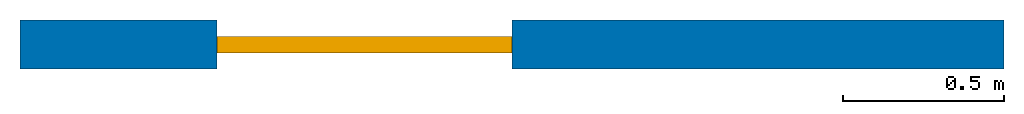
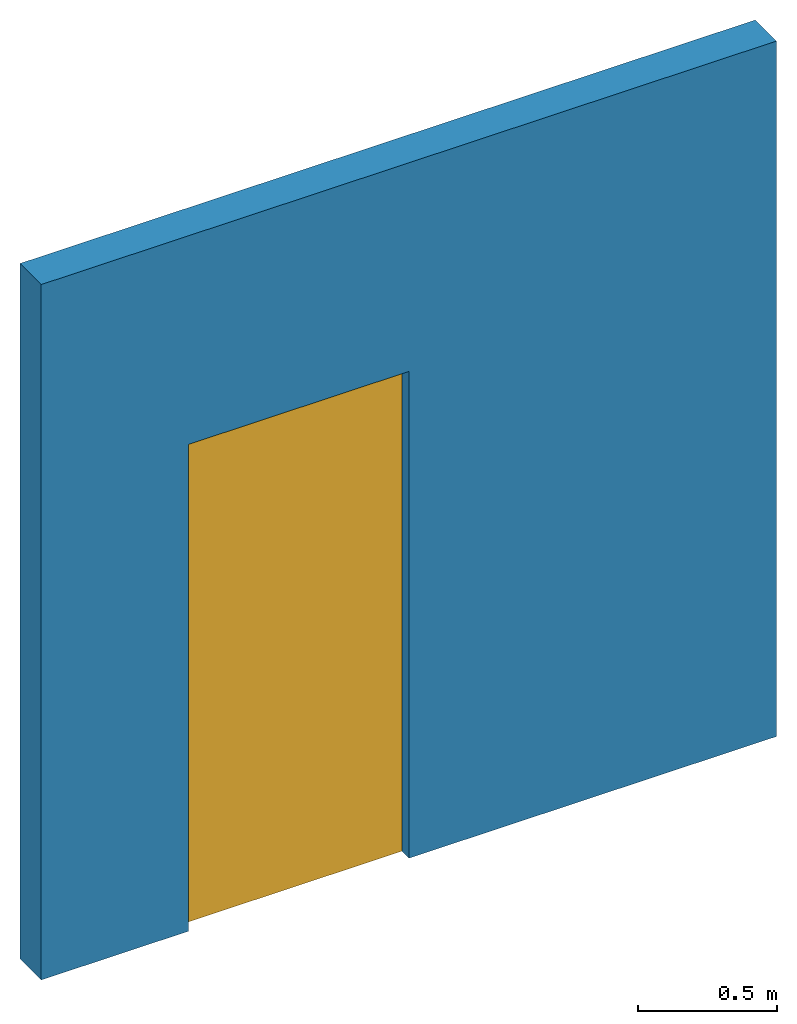
# One storey: 1 door, 1 wall, 1 opening.
"""IFC4 building model written with IfcOpenShell, lengths in feet."""

from ifc_helpers import new_model, entity, si_unit, converted_unit, derived_unit, direction, frame, frame_2d, origin, origin_2d_with_axis, place, context, subcontext, project, spatial, rectangle, extrude, source, transform, mapped, material, layer, layer_set, layer_usage, type_object, type_shapes, element, fill, save


model = new_model("IFC4")

# Units and contexts
model_context = context("Model", 3, precision=0.0001, world=origin(), true_north=direction((6.12303176911189e-17, 1.0)))
context_of_model = context(None, 3, precision=0.0001, world=origin(), true_north=direction((6.12303176911189e-17, 1.0)))
body_context = subcontext(model_context, "Body", "Model", "MODEL_VIEW")
ifc_project = project(units=[converted_unit("LENGTHUNIT", "FOOT", entity("IfcRatioMeasure", 0.3048), si_unit("LENGTHUNIT", "METRE"), dimensions=[1, 0, 0, 0, 0, 0, 0]), converted_unit("AREAUNIT", "SQUARE FOOT", entity("IfcRatioMeasure", 0.09290304), si_unit("AREAUNIT", "SQUARE_METRE"), dimensions=[2, 0, 0, 0, 0, 0, 0]), converted_unit("VOLUMEUNIT", "CUBIC FOOT", entity("IfcRatioMeasure", 0.028316846592), si_unit("VOLUMEUNIT", "CUBIC_METRE"), dimensions=[3, 0, 0, 0, 0, 0, 0]), converted_unit("PLANEANGLEUNIT", "DEGREE", entity("IfcRatioMeasure", 0.0174532925199433), si_unit("PLANEANGLEUNIT", "RADIAN"), dimensions=[0, 0, 0, 0, 0, 0, 0]), si_unit("MASSUNIT", "GRAM", prefix="KILO"), derived_unit("MASSDENSITYUNIT", [(si_unit("MASSUNIT", "GRAM", prefix="KILO"), 1), (si_unit("LENGTHUNIT", "METRE"), -3)]), si_unit("TIMEUNIT", "SECOND"), si_unit("FREQUENCYUNIT", "HERTZ"), si_unit("THERMODYNAMICTEMPERATUREUNIT", "DEGREE_CELSIUS"), derived_unit("THERMALTRANSMITTANCEUNIT", [(si_unit("MASSUNIT", "GRAM", prefix="KILO"), 1), (si_unit("THERMODYNAMICTEMPERATUREUNIT", "KELVIN"), -1), (si_unit("TIMEUNIT", "SECOND"), -3)]), derived_unit("VOLUMETRICFLOWRATEUNIT", [(si_unit("LENGTHUNIT", "METRE"), 3), (si_unit("TIMEUNIT", "SECOND"), -1)]), si_unit("ELECTRICCURRENTUNIT", "AMPERE"), si_unit("ELECTRICVOLTAGEUNIT", "VOLT"), si_unit("POWERUNIT", "WATT"), si_unit("FORCEUNIT", "NEWTON"), si_unit("ILLUMINANCEUNIT", "LUX"), si_unit("LUMINOUSFLUXUNIT", "LUMEN"), si_unit("LUMINOUSINTENSITYUNIT", "CANDELA"), derived_unit("USERDEFINED", [(si_unit("MASSUNIT", "GRAM", prefix="KILO"), -1), (si_unit("LENGTHUNIT", "METRE"), -2), (si_unit("TIMEUNIT", "SECOND"), 3), (si_unit("LUMINOUSFLUXUNIT", "LUMEN"), 1)]), derived_unit("LINEARVELOCITYUNIT", [(si_unit("LENGTHUNIT", "METRE"), 1), (si_unit("TIMEUNIT", "SECOND"), -1)]), si_unit("PRESSUREUNIT", "PASCAL"), derived_unit("USERDEFINED", [(si_unit("LENGTHUNIT", "METRE"), -2), (si_unit("MASSUNIT", "GRAM", prefix="KILO"), 1), (si_unit("TIMEUNIT", "SECOND"), -2)])], contexts=[model_context, context_of_model])

# Site, building, storey
site_placement = place(None, origin())
site = spatial("IfcSite", under=ifc_project, at=site_placement, CompositionType="ELEMENT")
building_placement = place(site_placement, origin())
building = spatial("IfcBuilding", under=site, at=building_placement, CompositionType="ELEMENT")
storey_placement = place(building_placement, origin())
storey = spatial("IfcBuildingStorey", under=building, at=storey_placement, Name="Level 1", CompositionType="ELEMENT", Elevation=0.0)

# Wall, opening, door
ifc_material = material(Name="Wall Material", Category="Materials")
ifc_layer = layer(ifc_material, 0.5, Name="Wall Material", Category="Materials")
ifc_layer_set = layer_set([ifc_layer], Name="Basic Wall:Wall Type")
ifc_layer_usage = layer_usage(ifc_layer_set, "AXIS2", "NEGATIVE", 0.25)
wall_type = type_object("IfcWallType", Name="Basic Wall:Wall Type", PredefinedType="NOTDEFINED", material=ifc_layer_set)
wall_placement = place(storey_placement, origin())
wall = element("IfcWall", 1, at=wall_placement, inside=storey, type_object=wall_type, material=ifc_layer_usage, Name="Basic Wall:Wall Type", ObjectType="Basic Wall:Wall Type", PredefinedType="NOTDEFINED", context=body_context, shape_type="SweptSolid", body=[
    extrude(rectangle(XDim=10.0, YDim=0.5, at=frame_2d((5.0, 0.0), x_axis=(-1.0, 0.0))), origin(), (0.0, 0.0, 1.0), 10.0),
])
opening_placement = place(wall_placement, frame((2.0, -0.25000000000001, 0.0)))
opening = element("IfcOpeningElement", 2, at=opening_placement, cuts=wall, ObjectType="Opening", PredefinedType="OPENING", context=body_context, shape_type="SweptSolid", body=[
    extrude(rectangle(XDim=7.0, YDim=3.0, at=frame_2d((3.5, 1.5), x_axis=(1.0, 0.0))), frame((0.0, 0.0, 0.0), z_axis=(0.0, 1.0, 0.0), x_axis=(0.0, 0.0, 1.0)), (0.0, 0.0, 1.0), 0.5),
])
door_type = type_object("IfcDoorType", OperationType="SINGLE_SWING_RIGHT", ParameterTakesPrecedence=False, PredefinedType="DOOR")
shared_shape = source(origin(), body_context, "Body", "SweptSolid", [
    extrude(rectangle(XDim=0.166666666666667, YDim=3.0, at=origin_2d_with_axis()), frame((1.5, 0.25, 0.0), z_axis=(0.0, 0.0, 1.0), x_axis=(0.0, 1.0, 0.0)), (0.0, 0.0, 1.0), 7.0),
])
type_shapes(door_type, [shared_shape])
door_placement = place(opening_placement, origin())
door = element("IfcDoor", 3, at=door_placement, inside=storey, type_object=door_type, OperationType="SINGLE_SWING_RIGHT", OverallHeight=7.0, OverallWidth=3.0, PredefinedType="DOOR", context=body_context, shape_type="MappedRepresentation", body=[
    mapped(shared_shape, transform((0.0, 0.0, 0.0), scale=1.0)),
])
fill(opening, door)

save(model, "model.ifc")
